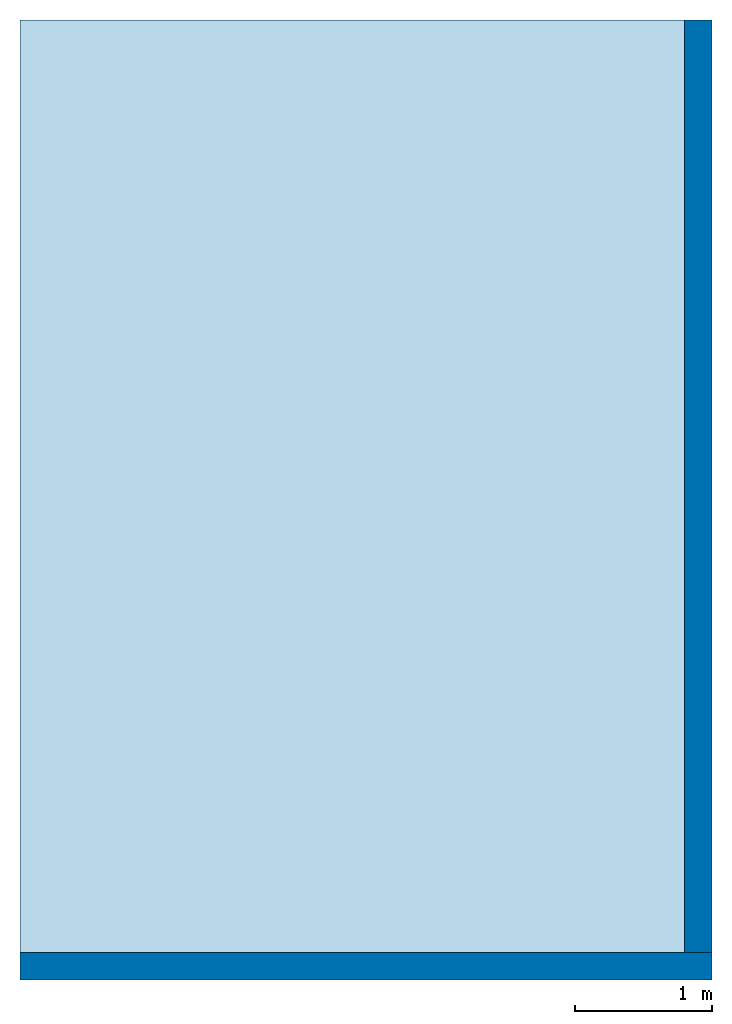
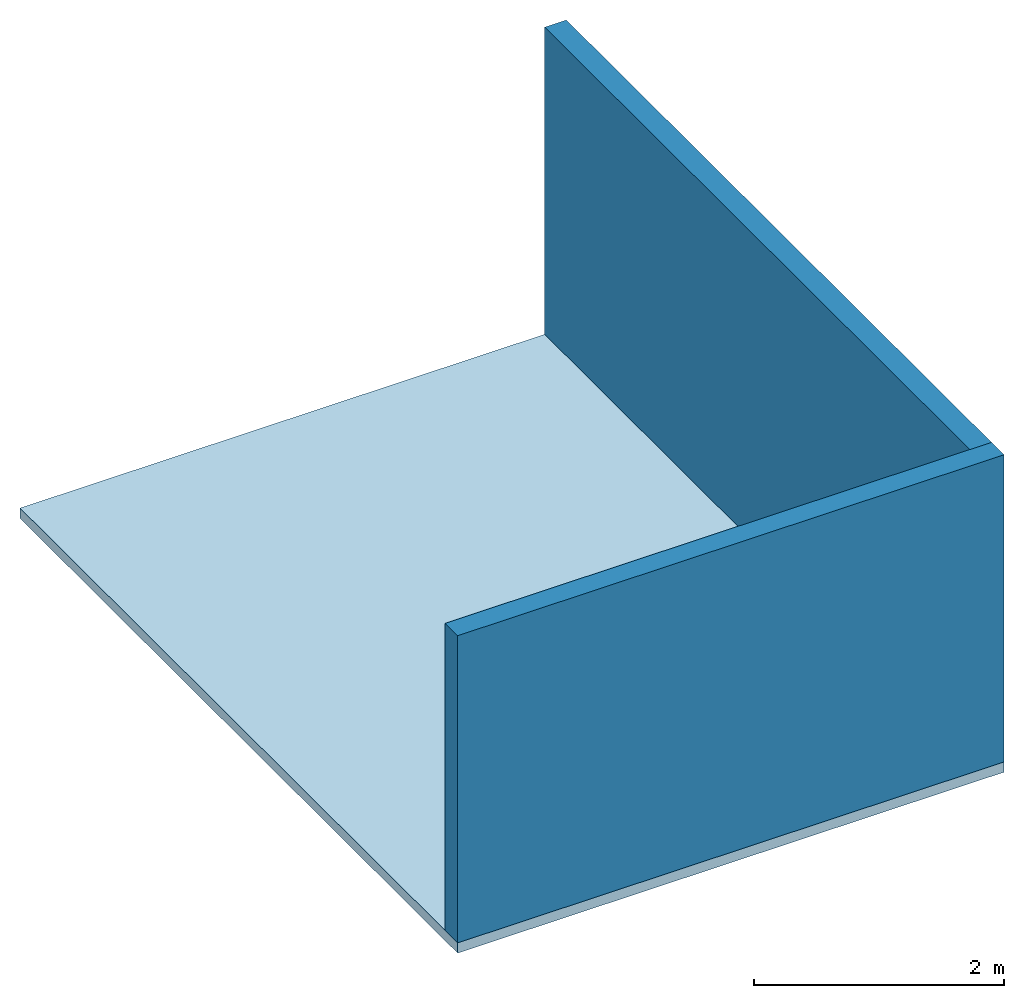
# One storey: 2 walls, 1 slab.
"""IFC4 building model written with IfcOpenShell, lengths in metres."""

from ifc_helpers import new_model, entity, si_unit, converted_unit, frame, origin_with_axes, origin_2d_with_axis, place, context, subcontext, project, spatial, line, indexed_curve, outline, extrude, material, layer, layer_set, layer_usage, type_object, element, save


model = new_model("IFC4")

# Units and contexts
model_context = context("Model", 3, precision=1e-05, world=origin_with_axes())
plan_context = context("Plan", 2, precision=1e-05, world=origin_2d_with_axis())
body_context = subcontext(model_context, "Body", "Model", "MODEL_VIEW")
ifc_project = project(units=[si_unit("VOLUMEUNIT", "CUBIC_METRE"), si_unit("LENGTHUNIT", "METRE"), converted_unit("PLANEANGLEUNIT", "degree", entity("IfcReal", 0.0174532925199433), si_unit("PLANEANGLEUNIT", "RADIAN"), dimensions=[0, 0, 0, 0, 0, 0, 0]), si_unit("AREAUNIT", "SQUARE_METRE")], contexts=[model_context, plan_context])

# Site, building, storey
site_placement = place(None, origin_with_axes())
site = spatial("IfcSite", under=ifc_project, at=site_placement)
building_placement = place(site_placement, origin_with_axes())
building = spatial("IfcBuilding", under=site, at=building_placement, Name="Building")
storey_placement = place(building_placement, origin_with_axes())
storey = spatial("IfcBuildingStorey", under=building, at=storey_placement, Name="Storey")

# Slab
ifc_material = material()
ifc_layer_1 = layer(ifc_material, 0.1)
ifc_layer_set_1 = layer_set([ifc_layer_1])
ifc_layer_usage_1 = layer_usage(ifc_layer_set_1, "AXIS3", "POSITIVE", 0.0)
slab_type = type_object("IfcSlabType", Name="slab", PredefinedType="FLOOR", material=ifc_layer_set_1)
slab_placement = place(storey_placement, frame((0.0, 0.0, -0.200000002980232), z_axis=(0.0, 0.0, 1.0), x_axis=(1.0, 0.0, 0.0)))
element("IfcSlab", 1, at=slab_placement, inside=storey, type_object=slab_type, material=ifc_layer_usage_1, Name="Slab", context=body_context, shape_type="SweptSolid", body=[
    extrude(outline(indexed_curve([(0.0, 0.0), (5.04724597930908, 0.0), (5.04724597930908, 7.00305032730103), (0.0, 7.00305032730103)], segments=[line(3, 2), line(2, 1), line(1, 4), line(4, 3)], self_intersect=False)), None, (0.0, 0.0, 1.0), 0.1),
])

# Walls
ifc_layer_2 = layer(ifc_material, 0.200000002980232)
ifc_layer_set_2 = layer_set([ifc_layer_2])
ifc_layer_usage_2 = layer_usage(ifc_layer_set_2, "AXIS2", "POSITIVE", 0.0)
wall_type = type_object("IfcWallType", Name="wall200", PredefinedType="SOLIDWALL", material=ifc_layer_set_2)
wall_1_placement = place(storey_placement, frame((0.0, 0.0, -0.100000001490116), z_axis=(0.0, 0.0, 1.0), x_axis=(1.0, 0.0, 0.0)))
element("IfcWall", 2, at=wall_1_placement, inside=storey, type_object=wall_type, material=ifc_layer_usage_2, Name="Wall", context=body_context, shape_type="SweptSolid", body=[
    extrude(outline(indexed_curve([(0.0, 0.0), (0.0, 0.200000002980232), (5.04724592139032, 0.200000002980232), (5.04724592139032, 0.0), (0.0, 0.0)], self_intersect=False)), origin_with_axes(), (0.0, 0.0, 1.0), 3.0),
])
ifc_layer_usage_3 = layer_usage(ifc_layer_set_2, "AXIS2", "POSITIVE", 0.0)
wall_2_placement = place(storey_placement, frame((5.04724597930908, 0.200000002980232, -0.100000001490116), z_axis=(0.0, 0.0, 1.0), x_axis=(7.54979012640431e-08, 0.999999999999997, 0.0)))
element("IfcWall", 3, at=wall_2_placement, inside=storey, type_object=wall_type, material=ifc_layer_usage_3, Name="Wall", context=body_context, shape_type="SweptSolid", body=[
    extrude(outline(indexed_curve([(0.0, 0.0), (0.0, 0.200000002980232), (6.80305063595166, 0.200000002980232), (6.80305063595166, 0.0), (0.0, 0.0)], self_intersect=False)), origin_with_axes(), (0.0, 0.0, 1.0), 3.0),
])

save(model, "model.ifc")
